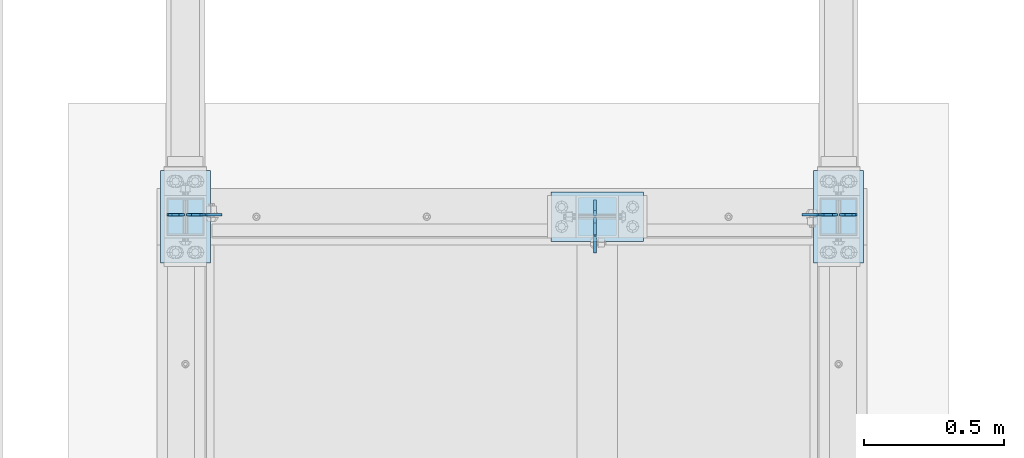
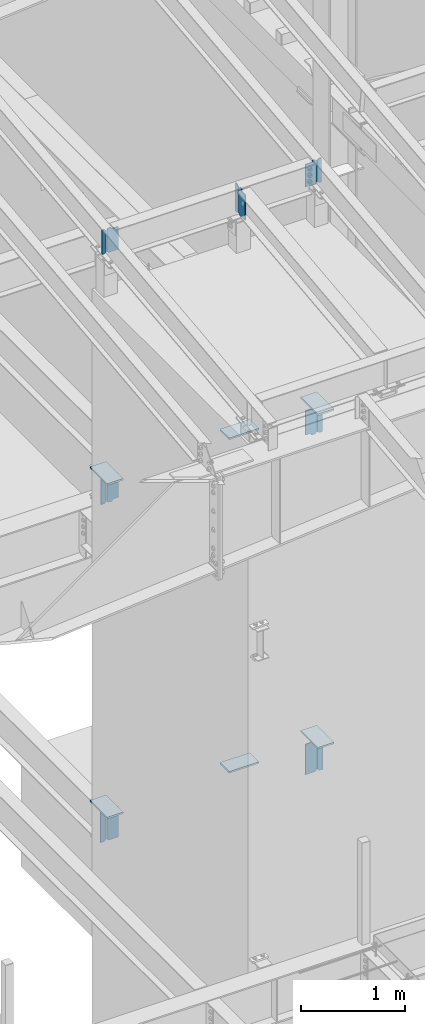
# One storey, part 1009 of 1179: 20 plates, 13 elements without a shape of their own.
"""IFC2X3 building model written with IfcOpenShell, lengths in millimetres."""

from ifc_helpers import new_model, si_unit, frame, origin_with_axes, place, context, subcontext, project, spatial, faceted_brep, material, type_object, element, aggregate, save


model = new_model("IFC2X3")

# Units and contexts
model_context = context("Model", 3, precision=1e-05, world=origin_with_axes())
body_context = subcontext(model_context, "Body", "Model", "MODEL_VIEW")
ifc_project = project(units=[si_unit("LENGTHUNIT", "METRE", prefix="MILLI"), si_unit("AREAUNIT", "SQUARE_METRE"), si_unit("VOLUMEUNIT", "CUBIC_METRE"), si_unit("MASSUNIT", "GRAM", prefix="KILO"), si_unit("TIMEUNIT", "SECOND"), si_unit("PLANEANGLEUNIT", "RADIAN"), si_unit("SOLIDANGLEUNIT", "STERADIAN"), si_unit("THERMODYNAMICTEMPERATUREUNIT", "DEGREE_CELSIUS"), si_unit("LUMINOUSINTENSITYUNIT", "LUMEN")], contexts=[model_context])

# Site, building, storey
site_placement = place(None, origin_with_axes())
site = spatial("IfcSite", under=ifc_project, at=site_placement, CompositionType="ELEMENT")
building_placement = place(site_placement, origin_with_axes())
building = spatial("IfcBuilding", under=site, at=building_placement, Name="Undefined", CompositionType="ELEMENT")
storey_placement = place(building_placement, origin_with_axes())
storey = spatial("IfcBuildingStorey", under=building, at=storey_placement, Name="Undefined", CompositionType="ELEMENT", Elevation=0.0)

# Assembly, plate
assembly_1_placement = place(storey_placement, origin_with_axes())
assembly_1 = element("IfcElementAssembly", 1, at=assembly_1_placement, inside=storey, Name="BEAM", AssemblyPlace="NOTDEFINED", PredefinedType="RIGID_FRAME")
ifc_material = material(Name="STEEL/A36")
plate_type_1 = type_object("IfcPlateType", PredefinedType="NOTDEFINED")
plate_1_placement = place(assembly_1_placement, frame((21479.175, 14670.0879999119, 10605.0592488381), z_axis=(0.0, 0.0, 1.0), x_axis=(1.0, 0.0, 0.0)))
plate_1 = element("IfcPlate", 2, at=plate_1_placement, type_object=plate_type_1, material=ifc_material, Name="PLATE", context=body_context, shape_type="Brep", body=[
    faceted_brep([(0.0, -4.76250000000073, 19.0499992370605), (0.0, -4.76250000000073, 266.862435780953), (0.0, 4.76250000000073, 266.862435780953), (0.0, 4.76250000000073, 19.0499992370605), (19.0499992370605, -4.76250000000073, 285.912435018014), (19.0499992370605, 4.76250000000073, 285.912435018014), (44.4500000000007, -4.76250000000073, 285.912435018014), (44.4500000000007, 4.76250000000073, 285.912435018014), (44.4500000000007, -4.76250000000073, 0.0), (44.4500000000007, 4.76250000000073, 0.0), (19.0499992370605, -4.76250000000073, 0.0), (19.0499992370605, 4.76250000000073, 0.0)], [[[0, 1, 2, 3]], [[1, 4, 5, 2]], [[4, 6, 7, 5]], [[6, 8, 9, 7]], [[8, 10, 11, 9]], [[10, 0, 3, 11]], [[5, 7, 9, 11, 3, 2]], [[10, 8, 6, 4, 1, 0]]]),
])

assembly_2_placement = place(storey_placement, origin_with_axes())
assembly_2 = element("IfcElementAssembly", 3, at=assembly_2_placement, inside=storey, Name="BEAM", AssemblyPlace="NOTDEFINED", PredefinedType="RIGID_FRAME")
plate_2_placement = place(assembly_2_placement, frame((19135.425, 14670.0879999119, 10605.0592488381), z_axis=(0.0, 0.0, 1.0), x_axis=(-1.0, 0.0, 0.0)))
plate_2 = element("IfcPlate", 4, at=plate_2_placement, type_object=plate_type_1, material=ifc_material, Name="PLATE", context=body_context, shape_type="Brep", body=[
    faceted_brep([(0.0, -4.76250000000073, 19.0499992370605), (0.0, -4.76250000000073, 266.862435780953), (0.0, 4.76250000000073, 266.862435780953), (0.0, 4.76250000000073, 19.0499992370605), (19.0499992370605, -4.76250000000073, 285.912435018014), (19.0499992370605, 4.76250000000073, 285.912435018014), (44.4500000000007, -4.76250000000073, 285.912435018014), (44.4500000000007, 4.76250000000073, 285.912435018014), (44.4500000000007, -4.76250000000073, 0.0), (44.4500000000007, 4.76250000000073, 0.0), (19.0499992370605, -4.76250000000073, 0.0), (19.0499992370605, 4.76250000000073, 0.0)], [[[0, 1, 2, 3]], [[1, 4, 5, 2]], [[4, 6, 7, 5]], [[6, 8, 9, 7]], [[8, 10, 11, 9]], [[10, 0, 3, 11]], [[5, 7, 9, 11, 3, 2]], [[10, 8, 6, 4, 1, 0]]]),
])

# Plate
plate_type_2 = type_object("IfcPlateType", PredefinedType="NOTDEFINED")
plate_3_placement = place(assembly_1_placement, frame((21472.225, 14670.0879999144, 10605.0592488384), z_axis=(0.0, 0.0, 1.0), x_axis=(-1.0, 0.0, 0.0)))
plate_3 = element("IfcPlate", 5, at=plate_3_placement, type_object=plate_type_2, material=ifc_material, Name="PLATE", context=body_context, shape_type="Brep", body=[
    faceted_brep([(47.3250000000007, -4.76250000000073, 285.912435018014), (47.3250000000007, -4.76250000000073, 278.748969282953), (47.3250000000007, 4.76250000000073, 278.748969282953), (47.3250000000007, 4.76250000000073, 285.912435018014), (48.2917299225883, -4.76250000000073, 273.888889764907), (48.2917299225883, 4.76250000000073, 273.888889764907), (51.0447438230658, -4.76250000000073, 269.768713296753), (51.0447438230658, 4.76250000000073, 269.768713296753), (55.1649202912195, -4.76250000000073, 267.015699396276), (55.1649202912195, 4.76250000000073, 267.015699396276), (60.0249998092659, -4.76250000000073, 266.048969473688), (60.0249998092659, 4.76250000000073, 266.048969473688), (127.0, -4.76250000000073, 266.048969473688), (127.0, 4.76250000000073, 266.048969473688), (0.0, -4.76250000000073, 266.862435780953), (19.0499992370605, -4.76250000000073, 285.912435018014), (19.0499992370605, 4.76250000000073, 285.912435018014), (0.0, 4.76250000000073, 266.862435780953), (0.0, -4.76250000000073, 19.0499992370605), (0.0, 4.76250000000073, 19.0499992370605), (19.0499992370605, -4.76250000000073, 0.0), (19.0499992370605, 4.76250000000073, 0.0), (127.0, -4.76250000000073, 0.0), (127.0, 4.76250000000073, 0.0)], [[[0, 1, 2, 3]], [[4, 5, 2, 1]], [[6, 7, 5, 4]], [[8, 9, 7, 6]], [[10, 11, 9, 8]], [[12, 13, 11, 10]], [[14, 15, 16, 17]], [[18, 14, 17, 19]], [[20, 18, 19, 21]], [[22, 20, 21, 23]], [[8, 6, 4, 1, 0, 15, 14, 18, 20, 22, 12, 10]], [[16, 15, 0, 3]], [[23, 21, 19, 17, 16, 3, 2, 5, 7, 9, 11, 13]], [[22, 23, 13, 12]]]),
])

aggregate(assembly_1, [plate_1, plate_3])

plate_4_placement = place(assembly_2_placement, frame((19142.375, 14670.0879999144, 10605.0592488384), z_axis=(0.0, 0.0, 1.0), x_axis=(1.0, 0.0, 0.0)))
plate_4 = element("IfcPlate", 6, at=plate_4_placement, type_object=plate_type_2, material=ifc_material, Name="PLATE", context=body_context, shape_type="Brep", body=[
    faceted_brep([(47.3250000000007, -4.76250000000073, 285.912435018014), (47.3250000000007, -4.76250000000073, 278.748969282953), (47.3250000000007, 4.76250000000073, 278.748969282953), (47.3250000000007, 4.76250000000073, 285.912435018014), (48.2917299225883, -4.76250000000073, 273.888889764907), (48.2917299225883, 4.76250000000073, 273.888889764907), (51.0447438230658, -4.76250000000073, 269.768713296753), (51.0447438230658, 4.76250000000073, 269.768713296753), (55.1649202912195, -4.76250000000073, 267.015699396276), (55.1649202912195, 4.76250000000073, 267.015699396276), (60.0249998092659, -4.76250000000073, 266.048969473688), (60.0249998092659, 4.76250000000073, 266.048969473688), (127.0, -4.76250000000073, 266.048969473688), (127.0, 4.76250000000073, 266.048969473688), (0.0, -4.76250000000073, 266.862435780953), (19.0499992370605, -4.76250000000073, 285.912435018014), (19.0499992370605, 4.76250000000073, 285.912435018014), (0.0, 4.76250000000073, 266.862435780953), (0.0, -4.76250000000073, 19.0499992370605), (0.0, 4.76250000000073, 19.0499992370605), (19.0499992370605, -4.76250000000073, 0.0), (19.0499992370605, 4.76250000000073, 0.0), (127.0, -4.76250000000073, 0.0), (127.0, 4.76250000000073, 0.0)], [[[0, 1, 2, 3]], [[4, 5, 2, 1]], [[6, 7, 5, 4]], [[8, 9, 7, 6]], [[10, 11, 9, 8]], [[12, 13, 11, 10]], [[14, 15, 16, 17]], [[18, 14, 17, 19]], [[20, 18, 19, 21]], [[22, 20, 21, 23]], [[8, 6, 4, 1, 0, 15, 14, 18, 20, 22, 12, 10]], [[16, 15, 0, 3]], [[23, 21, 19, 17, 16, 3, 2, 5, 7, 9, 11, 13]], [[22, 23, 13, 12]]]),
])

aggregate(assembly_2, [plate_2, plate_4])

# Assembly, plate
assembly_3_placement = place(storey_placement, origin_with_axes())
assembly_3 = element("IfcElementAssembly", 7, at=assembly_3_placement, inside=storey, Name="BEAM", AssemblyPlace="NOTDEFINED", PredefinedType="RIGID_FRAME")
plate_5_placement = place(assembly_3_placement, frame((20604.1620000841, 14658.975, 10556.7832183146), z_axis=(0.0, 0.0, 1.0), x_axis=(0.0, -1.0, 0.0)))
plate_5 = element("IfcPlate", 8, at=plate_5_placement, type_object=plate_type_2, material=ifc_material, Name="PLATE", context=body_context, shape_type="Brep", body=[
    faceted_brep([(60.3250000095268, -4.76250000000073, 330.200000000001), (60.32500011927, -4.76250000000073, 311.912083916155), (60.32500011927, 4.76250000000073, 311.912083916155), (60.3250000095268, 4.76250000000073, 330.200000000001), (61.2917300637309, -4.76250000000073, 307.052004421514), (61.2917300637309, 4.76250000000073, 307.052004421514), (64.0447439692816, -4.76250000000073, 302.931827979222), (64.0447439692816, 4.76250000000073, 302.931827979222), (68.164920428093, -4.76250000000073, 300.178814098397), (68.164920428093, 4.76250000000073, 300.178814098397), (73.0249999285352, -4.76250000000073, 299.2120841831), (73.0249999285352, 4.76250000000073, 299.2120841831), (127.0, -4.76250000000073, 299.212084183104), (127.0, 4.76250000000073, 299.212084183104), (0.0, -4.76250000000073, 311.150012969971), (19.0499992370605, -4.76250000000073, 330.200012207031), (19.0499992370605, 4.76250000000073, 330.200012207031), (0.0, 4.76250000000073, 311.150012969971), (0.0, -4.76250000000073, 19.0499992370605), (0.0, 4.76250000000073, 19.0499992370605), (19.0499992370605, -4.76250000000073, 0.0), (19.0499992370605, 4.76250000000073, 0.0), (127.0, -4.76250000000073, 0.0), (127.0, 4.76250000000073, 0.0)], [[[0, 1, 2, 3]], [[4, 5, 2, 1]], [[6, 7, 5, 4]], [[8, 9, 7, 6]], [[10, 11, 9, 8]], [[12, 13, 11, 10]], [[14, 15, 16, 17]], [[18, 14, 17, 19]], [[20, 18, 19, 21]], [[22, 20, 21, 23]], [[8, 6, 4, 1, 0, 15, 14, 18, 20, 22, 12, 10]], [[16, 15, 0, 3]], [[23, 21, 19, 17, 16, 3, 2, 5, 7, 9, 11, 13]], [[22, 23, 13, 12]]]),
])

assembly_4_placement = place(storey_placement, origin_with_axes())
assembly_4 = element("IfcElementAssembly", 9, at=assembly_4_placement, inside=storey, Name="BEAM", AssemblyPlace="NOTDEFINED", PredefinedType="RIGID_FRAME")
plate_6_placement = place(assembly_4_placement, frame((19142.075, 14670.0879999161, 7673.975), z_axis=(0.0, 0.0, 1.0), x_axis=(1.0, 0.0, 0.0)))
plate_6 = element("IfcPlate", 10, at=plate_6_placement, type_object=plate_type_2, material=ifc_material, Name="PLATE", context=body_context, shape_type="Brep", body=[
    faceted_brep([(60.3253379428825, -4.76250000000073, 330.2), (60.3251935182416, -4.76250000000073, 320.675192374972), (60.325194661229, 4.76250000000073, 320.675192374954), (60.3253390858881, 4.76250000000073, 330.2), (61.2918681696719, -4.76250000000073, 315.815053721808), (61.2918693126594, 4.76250000000073, 315.815053721791), (64.0448692547652, -4.76250000000073, 311.694811904253), (64.0448703977527, 4.76250000000073, 311.694811904235), (68.1650693271513, -4.76250000000073, 308.94174834285), (68.1650704701387, 4.76250000000073, 308.941748342832), (73.0251933217332, -4.76250000000073, 307.9749999956), (73.0251944647207, 4.76250000000073, 307.974999995583), (126.999999435993, -4.76250000000073, 307.975000020951), (127.0, 4.76250000000073, 307.975000020968), (0.0, -4.76250000000073, 311.150012969971), (19.0499992370605, -4.76250000000073, 330.200012207031), (19.0499992370605, 4.76250000000073, 330.200012207031), (0.0, 4.76250000000073, 311.150012969971), (0.0, -4.76250000000073, 19.0499992370605), (0.0, 4.76250000000073, 19.0499992370605), (19.0499992370605, -4.76250000000073, 0.0), (19.0499992370605, 4.76250000000073, 0.0), (60.3253631571861, 4.76250000000073, 0.0), (60.3253620141804, -4.76250000000073, 0.0), (60.3253631571679, 4.76250000000073, 9.52500019075978), (60.3253620141804, -4.76250000000073, 9.52500019075978), (61.2920930797518, 4.76250000000073, 14.3850797087989), (61.2920919367643, -4.76250000000073, 14.3850797087989), (64.0451069802257, 4.76250000000073, 18.5052561769489), (64.0451058372382, -4.76250000000073, 18.5052561769489), (68.1652834483721, 4.76250000000073, 21.2582700774283), (68.165282305381, -4.76250000000073, 21.2582700774283), (73.0253629664076, 4.76250000000073, 22.2250000000231), (73.0253618234201, -4.76250000000073, 22.2250000000231), (126.999999429587, -4.76250000000073, 22.2250000001213), (127.0, 4.76250000000073, 22.2250000001213)], [[[0, 1, 2, 3]], [[4, 5, 2, 1]], [[6, 7, 5, 4]], [[8, 9, 7, 6]], [[10, 11, 9, 8]], [[12, 13, 11, 10]], [[14, 15, 16, 17]], [[18, 14, 17, 19]], [[20, 18, 19, 21]], [[20, 21, 22, 23]], [[23, 22, 24, 25]], [[25, 24, 26, 27]], [[27, 26, 28, 29]], [[29, 28, 30, 31]], [[31, 30, 32, 33]], [[34, 33, 32, 35]], [[8, 6, 4, 1, 0, 15, 14, 18, 20, 23, 25, 27, 29, 31, 33, 34, 12, 10]], [[16, 15, 0, 3]], [[35, 32, 30, 28, 26, 24, 22, 21, 19, 17, 16, 3, 2, 5, 7, 9, 11, 13]], [[13, 12, 34, 35]]]),
])

assembly_5_placement = place(storey_placement, origin_with_axes())
assembly_5 = element("IfcElementAssembly", 11, at=assembly_5_placement, inside=storey, Name="BEAM", AssemblyPlace="NOTDEFINED", PredefinedType="RIGID_FRAME")
plate_7_placement = place(assembly_5_placement, frame((21472.525, 14670.0879999161, 7673.975), z_axis=(0.0, 0.0, 1.0), x_axis=(-1.0, 0.0, 0.0)))
plate_7 = element("IfcPlate", 12, at=plate_7_placement, type_object=plate_type_2, material=ifc_material, Name="PLATE", context=body_context, shape_type="Brep", body=[
    faceted_brep([(60.3246368427681, -4.76250000000073, 0.0), (60.3246379857737, 4.76250000000073, 0.0), (60.3246379857519, 4.76250000000073, 9.52500019075796), (60.3246368427644, -4.76250000000073, 9.52500019075796), (61.2913679083395, 4.76250000000073, 14.385079708798), (61.291366765352, -4.76250000000073, 14.385079708798), (64.0443818088097, 4.76250000000073, 18.5052561769489), (64.0443806658222, -4.76250000000073, 18.5052561769489), (68.1645582769561, 4.76250000000073, 21.2582700774283), (68.1645571339686, -4.76250000000073, 21.2582700774283), (73.0246377949952, 4.76250000000073, 22.2250000000231), (73.0246366520078, -4.76250000000073, 22.2250000000231), (126.999999429587, -4.76250000000073, 22.2250000001213), (127.0, 4.76250000000073, 22.2250000001213), (19.0499992370605, -4.76250000000073, 0.0), (0.0, -4.76250000000073, 19.0499992370605), (0.0, 4.76250000000073, 19.0499992370605), (19.0499992370605, 4.76250000000073, 0.0), (0.0, -4.76250000000073, 311.150012969971), (0.0, 4.76250000000073, 311.150012969971), (19.0499992370605, -4.76250000000073, 330.200012207031), (19.0499992370605, 4.76250000000073, 330.200012207031), (60.3246609394155, -4.76250000000073, 330.2), (60.3246620824211, 4.76250000000073, 330.2), (60.3248055223376, -4.76250000000073, 320.674807040034), (60.324806665325, 4.76250000000073, 320.674807040051), (61.2915907729657, -4.76250000000073, 315.814786720205), (61.2915919159532, 4.76250000000073, 315.814786720222), (64.0446175012585, -4.76250000000073, 311.694675670333), (64.0446186442459, 4.76250000000073, 311.69467567035), (68.1647703397102, -4.76250000000073, 308.941711482811), (68.1647714826977, 4.76250000000073, 308.941711482828), (73.0248053341093, -4.76250000000073, 307.975000004066), (73.0248064770967, 4.76250000000073, 307.975000004083), (126.999999435993, -4.76250000000073, 307.975000020951), (127.0, 4.76250000000073, 307.975000020968)], [[[0, 1, 2, 3]], [[3, 2, 4, 5]], [[5, 4, 6, 7]], [[7, 6, 8, 9]], [[9, 8, 10, 11]], [[12, 11, 10, 13]], [[14, 15, 16, 17]], [[15, 18, 19, 16]], [[18, 20, 21, 19]], [[21, 20, 22, 23]], [[22, 24, 25, 23]], [[26, 27, 25, 24]], [[28, 29, 27, 26]], [[30, 31, 29, 28]], [[32, 33, 31, 30]], [[34, 35, 33, 32]], [[35, 34, 12, 13]], [[8, 6, 4, 2, 1, 17, 16, 19, 21, 23, 25, 27, 29, 31, 33, 35, 13, 10]], [[14, 17, 1, 0]], [[34, 32, 30, 28, 26, 24, 22, 20, 18, 15, 14, 0, 3, 5, 7, 9, 11, 12]]]),
])

assembly_6_placement = place(storey_placement, origin_with_axes())
assembly_6 = element("IfcElementAssembly", 13, at=assembly_6_placement, inside=storey, Name="BEAM", AssemblyPlace="NOTDEFINED", PredefinedType="RIGID_FRAME")
plate_8_placement = place(assembly_6_placement, frame((19142.075, 14670.0879999161, 3711.575), z_axis=(0.0, 0.0, 1.0), x_axis=(1.0, 0.0, 0.0)))
plate_8 = element("IfcPlate", 14, at=plate_8_placement, type_object=plate_type_2, material=ifc_material, Name="PLATE", context=body_context, shape_type="Brep", body=[
    faceted_brep([(66.6743865212811, -4.76249999999709, 377.825), (66.6745864763507, -4.76249999999709, 371.474599924168), (66.6745876193563, 4.76249999999709, 371.474599924203), (66.6743876643031, 4.76249999999709, 377.825), (67.6414311678836, -4.76249999999709, 366.614643208318), (67.6414323108893, 4.76249999999709, 366.614643208353), (70.3944716748138, -4.76249999999709, 362.494602443389), (70.3944728178176, 4.76249999999709, 362.494602443423), (74.5145991226364, -4.76249999999709, 359.741691665477), (74.514600265642, 4.76249999999709, 359.741691665511), (79.3745862790947, -4.76249999999709, 358.774999999796), (79.3745874221004, 4.76249999999709, 358.774999999831), (127.000000004868, -4.76249999999709, 358.774999992755), (127.0, 4.76249999999709, 358.774999992755), (0.0, -4.76249999999709, 358.775000762939), (19.0499992370605, -4.76249999999709, 377.825), (19.0499992370605, 4.76249999999709, 377.825), (0.0, 4.76249999999709, 358.775000762939), (0.0, -4.76250000000073, 19.0499992370605), (0.0, 4.76250000000073, 19.0499992370605), (19.0499992370605, -4.76250000000073, 0.0), (19.0499992370605, 4.76250000000073, 0.0), (127.0, -4.76250000000073, 0.0), (127.0, 4.76250000000073, 0.0)], [[[0, 1, 2, 3]], [[4, 5, 2, 1]], [[6, 7, 5, 4]], [[8, 9, 7, 6]], [[10, 11, 9, 8]], [[12, 13, 11, 10]], [[14, 15, 16, 17]], [[18, 14, 17, 19]], [[20, 18, 19, 21]], [[22, 20, 21, 23]], [[8, 6, 4, 1, 0, 15, 14, 18, 20, 22, 12, 10]], [[16, 15, 0, 3]], [[23, 21, 19, 17, 16, 3, 2, 5, 7, 9, 11, 13]], [[22, 23, 13, 12]]]),
])

assembly_7_placement = place(storey_placement, origin_with_axes())
assembly_7 = element("IfcElementAssembly", 15, at=assembly_7_placement, inside=storey, Name="BEAM", AssemblyPlace="NOTDEFINED", PredefinedType="RIGID_FRAME")
plate_9_placement = place(assembly_7_placement, frame((21472.525, 14670.0879999161, 3711.575), z_axis=(0.0, 0.0, 1.0), x_axis=(-1.0, 0.0, 0.0)))
plate_9 = element("IfcPlate", 16, at=plate_9_placement, type_object=plate_type_2, material=ifc_material, Name="PLATE", context=body_context, shape_type="Brep", body=[
    faceted_brep([(66.6756118831599, -4.76249999999709, 377.825), (66.6754110961774, -4.76249999999709, 371.475401414235), (66.6754122391831, 4.76249999999709, 371.4754014142), (66.675613026182, 4.76249999999709, 377.825), (67.6420257521768, -4.76249999999709, 366.615198568966), (67.6420268951824, 4.76249999999709, 366.615198568931), (70.3950129291698, -4.76249999999709, 362.494885814615), (70.3950140721736, 4.76249999999709, 362.49488581458), (74.5152386277114, -4.76249999999709, 359.741768348284), (74.515239770717, 4.76249999999709, 359.741768348249), (79.3754109046859, -4.76249999999709, 358.775000005575), (79.3754120476915, 4.76249999999709, 358.775000005541), (127.000000004868, -4.76249999999709, 358.774999992755), (127.0, 4.76249999999709, 358.774999992755), (0.0, -4.76249999999709, 358.775000762939), (19.0499992370605, -4.76249999999709, 377.825), (19.0499992370605, 4.76249999999709, 377.825), (0.0, 4.76249999999709, 358.775000762939), (0.0, -4.76250000000073, 19.0499992370605), (0.0, 4.76250000000073, 19.0499992370605), (19.0499992370605, -4.76250000000073, 0.0), (19.0499992370605, 4.76250000000073, 0.0), (127.0, -4.76250000000073, 0.0), (127.0, 4.76250000000073, 0.0)], [[[0, 1, 2, 3]], [[4, 5, 2, 1]], [[6, 7, 5, 4]], [[8, 9, 7, 6]], [[10, 11, 9, 8]], [[12, 13, 11, 10]], [[14, 15, 16, 17]], [[18, 14, 17, 19]], [[20, 18, 19, 21]], [[22, 20, 21, 23]], [[8, 6, 4, 1, 0, 15, 14, 18, 20, 22, 12, 10]], [[16, 15, 0, 3]], [[23, 21, 19, 17, 16, 3, 2, 5, 7, 9, 11, 13]], [[22, 23, 13, 12]]]),
])

# Plate
plate_type_3 = type_object("IfcPlateType", PredefinedType="NOTDEFINED")
plate_10_placement = place(assembly_3_placement, frame((20604.1620000841, 14665.325, 10556.7832183146), z_axis=(0.0, 0.0, 1.0), x_axis=(0.0, 1.0, 0.0)))
plate_10 = element("IfcPlate", 17, at=plate_10_placement, type_object=plate_type_3, material=ifc_material, Name="PLATE", context=body_context, shape_type="Brep", body=[
    faceted_brep([(0.0, -4.76250000000073, 19.0499992370605), (0.0, -4.76250000000073, 311.150012969971), (0.0, 4.76250000000073, 311.150012969971), (0.0, 4.76250000000073, 19.0499992370605), (19.0499992370605, -4.76250000000073, 330.200012207031), (19.0499992370605, 4.76250000000073, 330.200012207031), (57.1500015258789, -4.76250000000073, 330.200012207031), (57.1500015258789, 4.76250000000073, 330.200012207031), (57.1500015258789, -4.76250000000073, 0.0), (57.1500015258789, 4.76250000000073, 0.0), (19.0499992370605, -4.76250000000073, 0.0), (19.0499992370605, 4.76250000000073, 0.0)], [[[0, 1, 2, 3]], [[1, 4, 5, 2]], [[4, 6, 7, 5]], [[6, 8, 9, 7]], [[8, 10, 11, 9]], [[10, 0, 3, 11]], [[5, 7, 9, 11, 3, 2]], [[10, 8, 6, 4, 1, 0]]]),
])

aggregate(assembly_3, [plate_10, plate_5])

plate_11_placement = place(assembly_4_placement, frame((19135.725, 14670.0879999161, 7673.975), z_axis=(0.0, 0.0, 1.0), x_axis=(-1.0, 0.0, 0.0)))
plate_11 = element("IfcPlate", 18, at=plate_11_placement, type_object=plate_type_3, material=ifc_material, Name="PLATE", context=body_context, shape_type="Brep", body=[
    faceted_brep([(0.0, -4.76250000000073, 19.0499992370605), (0.0, -4.76250000000073, 311.150012969971), (0.0, 4.76250000000073, 311.150012969971), (0.0, 4.76250000000073, 19.0499992370605), (19.0499992370605, -4.76250000000073, 330.200012207031), (19.0499992370605, 4.76250000000073, 330.200012207031), (57.1500015258789, -4.76250000000073, 330.200012207031), (57.1500015258789, 4.76250000000073, 330.200012207031), (57.1500015258789, -4.76250000000073, 0.0), (57.1500015258789, 4.76250000000073, 0.0), (19.0499992370605, -4.76250000000073, 0.0), (19.0499992370605, 4.76250000000073, 0.0)], [[[0, 1, 2, 3]], [[1, 4, 5, 2]], [[4, 6, 7, 5]], [[6, 8, 9, 7]], [[8, 10, 11, 9]], [[10, 0, 3, 11]], [[5, 7, 9, 11, 3, 2]], [[10, 8, 6, 4, 1, 0]]]),
])

aggregate(assembly_4, [plate_11, plate_6])

plate_12_placement = place(assembly_5_placement, frame((21478.875, 14670.0879999161, 7673.975), z_axis=(0.0, 0.0, 1.0), x_axis=(1.0, 0.0, 0.0)))
plate_12 = element("IfcPlate", 19, at=plate_12_placement, type_object=plate_type_3, material=ifc_material, Name="PLATE", context=body_context, shape_type="Brep", body=[
    faceted_brep([(0.0, -4.76250000000073, 19.0499992370605), (0.0, -4.76250000000073, 311.150012969971), (0.0, 4.76250000000073, 311.150012969971), (0.0, 4.76250000000073, 19.0499992370605), (19.0499992370605, -4.76250000000073, 330.200012207031), (19.0499992370605, 4.76250000000073, 330.200012207031), (57.1500015258789, -4.76250000000073, 330.200012207031), (57.1500015258789, 4.76250000000073, 330.200012207031), (57.1500015258789, -4.76250000000073, 0.0), (57.1500015258789, 4.76250000000073, 0.0), (19.0499992370605, -4.76250000000073, 0.0), (19.0499992370605, 4.76250000000073, 0.0)], [[[0, 1, 2, 3]], [[1, 4, 5, 2]], [[4, 6, 7, 5]], [[6, 8, 9, 7]], [[8, 10, 11, 9]], [[10, 0, 3, 11]], [[5, 7, 9, 11, 3, 2]], [[10, 8, 6, 4, 1, 0]]]),
])

aggregate(assembly_5, [plate_12, plate_7])

# Assembly, plate
assembly_8_placement = place(storey_placement, origin_with_axes())
assembly_8 = element("IfcElementAssembly", 20, at=assembly_8_placement, inside=storey, Name="COLUMN", AssemblyPlace="NOTDEFINED", PredefinedType="RIGID_FRAME")
plate_type_4 = type_object("IfcPlateType", PredefinedType="NOTDEFINED")
plate_13_placement = place(assembly_8_placement, frame((19050.0, 14497.05, 4111.625), z_axis=(0.0, 1.0, 0.0), x_axis=(1.0, 0.0, 0.0)))
plate_13 = element("IfcPlate", 21, at=plate_13_placement, type_object=plate_type_4, material=ifc_material, Name="PLATE", context=body_context, shape_type="Brep", body=[
    faceted_brep([(0.0, -9.52499999999964, 0.0), (0.0, -9.52499999999964, 330.200012207031), (0.0, 9.52499999999964, 330.200012207031), (0.0, 9.52499999999964, 0.0), (177.800003051758, -9.52499999999964, 330.200012207031), (177.800003051758, 9.52499999999964, 330.200012207031), (177.800003051758, -9.52499999999964, 0.0), (177.800003051758, 9.52499999999964, 0.0)], [[[0, 1, 2, 3]], [[1, 4, 5, 2]], [[4, 6, 7, 5]], [[6, 0, 3, 7]], [[5, 7, 3, 2]], [[6, 4, 1, 0]]]),
])
aggregate(assembly_8, [plate_13])

assembly_9_placement = place(storey_placement, origin_with_axes())
assembly_9 = element("IfcElementAssembly", 22, at=assembly_9_placement, inside=storey, Name="COLUMN", AssemblyPlace="NOTDEFINED", PredefinedType="RIGID_FRAME")
plate_14_placement = place(assembly_9_placement, frame((21386.8, 14497.05, 4111.625), z_axis=(0.0, 1.0, 0.0), x_axis=(1.0, 0.0, 0.0)))
plate_14 = element("IfcPlate", 23, at=plate_14_placement, type_object=plate_type_4, material=ifc_material, Name="PLATE", context=body_context, shape_type="Brep", body=[
    faceted_brep([(0.0, -9.52499999999964, 0.0), (0.0, -9.52499999999964, 330.200012207031), (0.0, 9.52499999999964, 330.200012207031), (0.0, 9.52499999999964, 0.0), (177.800003051758, -9.52499999999964, 330.200012207031), (177.800003051758, 9.52499999999964, 330.200012207031), (177.800003051758, -9.52499999999964, 0.0), (177.800003051758, 9.52499999999964, 0.0)], [[[0, 1, 2, 3]], [[1, 4, 5, 2]], [[4, 6, 7, 5]], [[6, 0, 3, 7]], [[5, 7, 3, 2]], [[6, 4, 1, 0]]]),
])
aggregate(assembly_9, [plate_14])

assembly_10_placement = place(storey_placement, origin_with_axes())
assembly_10 = element("IfcElementAssembly", 24, at=assembly_10_placement, inside=storey, Name="COLUMN", AssemblyPlace="NOTDEFINED", PredefinedType="RIGID_FRAME")
plate_15_placement = place(assembly_10_placement, frame((20447.0, 14751.05, 4111.625), z_axis=(1.0, 0.0, 0.0), x_axis=(0.0, -1.0, 0.0)))
plate_15 = element("IfcPlate", 25, at=plate_15_placement, type_object=plate_type_4, material=ifc_material, Name="PLATE", context=body_context, shape_type="Brep", body=[
    faceted_brep([(0.0, -9.52499999999964, 0.0), (0.0, -9.52499999999964, 330.200012207031), (0.0, 9.52499999999964, 330.200012207031), (0.0, 9.52499999999964, 0.0), (177.800003051758, -9.52499999999964, 330.200012207031), (177.800003051758, 9.52499999999964, 330.200012207031), (177.800003051758, -9.52499999999964, 0.0), (177.800003051758, 9.52499999999964, 0.0)], [[[0, 1, 2, 3]], [[1, 4, 5, 2]], [[4, 6, 7, 5]], [[6, 0, 3, 7]], [[5, 7, 3, 2]], [[6, 4, 1, 0]]]),
])
aggregate(assembly_10, [plate_15])

assembly_11_placement = place(storey_placement, origin_with_axes())
assembly_11 = element("IfcElementAssembly", 26, at=assembly_11_placement, inside=storey, Name="COLUMN", AssemblyPlace="NOTDEFINED", PredefinedType="RIGID_FRAME")
plate_16_placement = place(assembly_11_placement, frame((19050.0, 14497.05, 8023.225), z_axis=(0.0, 1.0, 0.0), x_axis=(1.0, 0.0, 0.0)))
plate_16 = element("IfcPlate", 27, at=plate_16_placement, type_object=plate_type_4, material=ifc_material, Name="PLATE", context=body_context, shape_type="Brep", body=[
    faceted_brep([(0.0, -9.52499999999964, 0.0), (0.0, -9.52499999999964, 330.200012207031), (0.0, 9.52499999999964, 330.200012207031), (0.0, 9.52499999999964, 0.0), (177.800003051758, -9.52499999999964, 330.200012207031), (177.800003051758, 9.52499999999964, 330.200012207031), (177.800003051758, -9.52499999999964, 0.0), (177.800003051758, 9.52499999999964, 0.0)], [[[0, 1, 2, 3]], [[1, 4, 5, 2]], [[4, 6, 7, 5]], [[6, 0, 3, 7]], [[5, 7, 3, 2]], [[6, 4, 1, 0]]]),
])
aggregate(assembly_11, [plate_16])

assembly_12_placement = place(storey_placement, origin_with_axes())
assembly_12 = element("IfcElementAssembly", 28, at=assembly_12_placement, inside=storey, Name="COLUMN", AssemblyPlace="NOTDEFINED", PredefinedType="RIGID_FRAME")
plate_17_placement = place(assembly_12_placement, frame((21386.8, 14497.05, 8023.225), z_axis=(0.0, 1.0, 0.0), x_axis=(1.0, 0.0, 0.0)))
plate_17 = element("IfcPlate", 29, at=plate_17_placement, type_object=plate_type_4, material=ifc_material, Name="PLATE", context=body_context, shape_type="Brep", body=[
    faceted_brep([(0.0, -9.52499999999964, 0.0), (0.0, -9.52499999999964, 330.200012207031), (0.0, 9.52499999999964, 330.200012207031), (0.0, 9.52499999999964, 0.0), (177.800003051758, -9.52499999999964, 330.200012207031), (177.800003051758, 9.52499999999964, 330.200012207031), (177.800003051758, -9.52499999999964, 0.0), (177.800003051758, 9.52499999999964, 0.0)], [[[0, 1, 2, 3]], [[1, 4, 5, 2]], [[4, 6, 7, 5]], [[6, 0, 3, 7]], [[5, 7, 3, 2]], [[6, 4, 1, 0]]]),
])
aggregate(assembly_12, [plate_17])

assembly_13_placement = place(storey_placement, origin_with_axes())
assembly_13 = element("IfcElementAssembly", 30, at=assembly_13_placement, inside=storey, Name="COLUMN", AssemblyPlace="NOTDEFINED", PredefinedType="RIGID_FRAME")
plate_18_placement = place(assembly_13_placement, frame((20447.0, 14751.05, 8023.225), z_axis=(1.0, 0.0, 0.0), x_axis=(0.0, -1.0, 0.0)))
plate_18 = element("IfcPlate", 31, at=plate_18_placement, type_object=plate_type_4, material=ifc_material, Name="PLATE", context=body_context, shape_type="Brep", body=[
    faceted_brep([(0.0, -9.52499999999964, 0.0), (0.0, -9.52499999999964, 330.200012207031), (0.0, 9.52499999999964, 330.200012207031), (0.0, 9.52499999999964, 0.0), (177.800003051758, -9.52499999999964, 330.200012207031), (177.800003051758, 9.52499999999964, 330.200012207031), (177.800003051758, -9.52499999999964, 0.0), (177.800003051758, 9.52499999999964, 0.0)], [[[0, 1, 2, 3]], [[1, 4, 5, 2]], [[4, 6, 7, 5]], [[6, 0, 3, 7]], [[5, 7, 3, 2]], [[6, 4, 1, 0]]]),
])
aggregate(assembly_13, [plate_18])

# Plate
plate_type_5 = type_object("IfcPlateType", PredefinedType="NOTDEFINED")
plate_19_placement = place(assembly_6_placement, frame((19135.725, 14670.0879999161, 3711.575), z_axis=(0.0, 0.0, 1.0), x_axis=(-1.0, 0.0, 0.0)))
plate_19 = element("IfcPlate", 32, at=plate_19_placement, type_object=plate_type_5, material=ifc_material, Name="PLATE", context=body_context, shape_type="Brep", body=[
    faceted_brep([(0.0, -4.76250000000073, 19.0499992370605), (0.0, -4.76249999999709, 358.775000762939), (0.0, 4.76249999999709, 358.775000762939), (0.0, 4.76250000000073, 19.0499992370605), (19.0499992370605, -4.76249999999709, 377.825), (19.0499992370605, 4.76249999999709, 377.825), (63.5, -4.76250000000073, 377.825012207031), (63.5, 4.76250000000073, 377.825012207031), (63.5, -4.76250000000073, 0.0), (63.5, 4.76250000000073, 0.0), (19.0499992370605, -4.76250000000073, 0.0), (19.0499992370605, 4.76250000000073, 0.0)], [[[0, 1, 2, 3]], [[1, 4, 5, 2]], [[4, 6, 7, 5]], [[6, 8, 9, 7]], [[8, 10, 11, 9]], [[10, 0, 3, 11]], [[5, 7, 9, 11, 3, 2]], [[10, 8, 6, 4, 1, 0]]]),
])

aggregate(assembly_6, [plate_19, plate_8])

plate_20_placement = place(assembly_7_placement, frame((21478.875, 14670.0881188012, 3711.575), z_axis=(0.0, 0.0, 1.0), x_axis=(1.0, 0.0, 0.0)))
plate_20 = element("IfcPlate", 33, at=plate_20_placement, type_object=plate_type_5, material=ifc_material, Name="PLATE", context=body_context, shape_type="Brep", body=[
    faceted_brep([(0.0, -4.76250000000073, 19.0499992370605), (0.0, -4.76249999999709, 358.775000762939), (0.0, 4.76249999999709, 358.775000762939), (0.0, 4.76250000000073, 19.0499992370605), (19.0499992370605, -4.76249999999709, 377.825), (19.0499992370605, 4.76249999999709, 377.825), (63.5, -4.76250000000073, 377.825012207031), (63.5, 4.76250000000073, 377.825012207031), (63.5, -4.76250000000073, 0.0), (63.5, 4.76250000000073, 0.0), (19.0499992370605, -4.76250000000073, 0.0), (19.0499992370605, 4.76250000000073, 0.0)], [[[0, 1, 2, 3]], [[1, 4, 5, 2]], [[4, 6, 7, 5]], [[6, 8, 9, 7]], [[8, 10, 11, 9]], [[10, 0, 3, 11]], [[5, 7, 9, 11, 3, 2]], [[10, 8, 6, 4, 1, 0]]]),
])

aggregate(assembly_7, [plate_20, plate_9])

save(model, "model.ifc")
